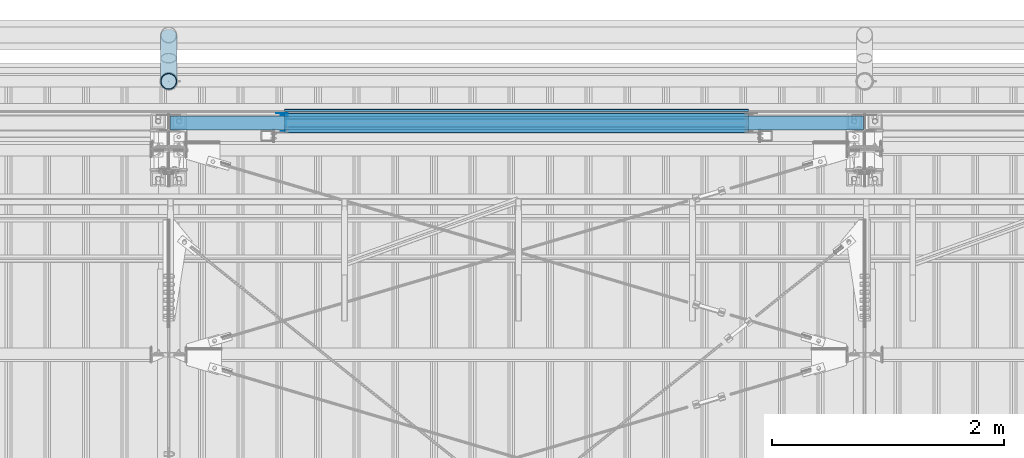
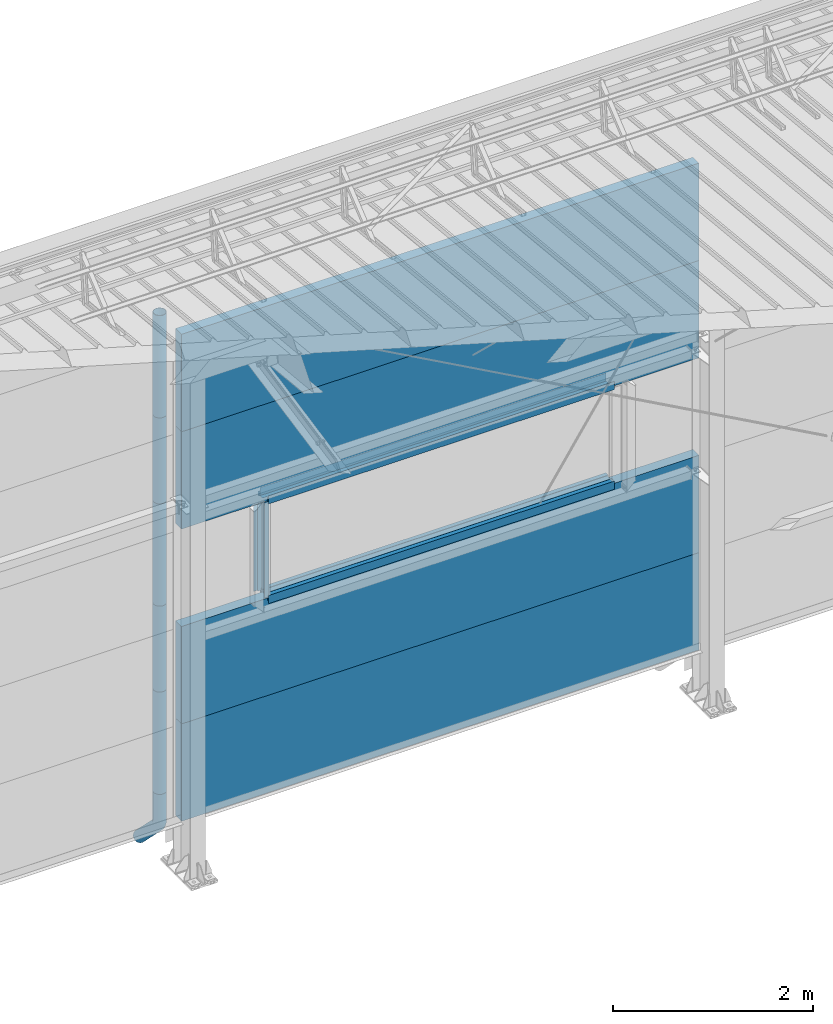
# One storey, part 78 of 709: 19 beams, 19 elements without a shape of their own.
"""IFC4 building model written with IfcOpenShell, lengths in millimetres."""

from ifc_helpers import new_model, entity, si_unit, direction, frame, origin_with_axes, place, context, subcontext, project, spatial, line, indexed_curve, outline, extrude, material, element, aggregate, save


model = new_model("IFC4")

# Units and contexts
model_context = context("Model", 3, precision=0.2, world=origin_with_axes(), true_north=direction((0.0, 1.0)))
body_context = subcontext(model_context, "Body", "Model", "MODEL_VIEW")
ifc_project = project(units=[si_unit("LENGTHUNIT", "METRE", prefix="MILLI"), si_unit("AREAUNIT", "SQUARE_METRE"), si_unit("VOLUMEUNIT", "CUBIC_METRE"), si_unit("MASSUNIT", "GRAM", prefix="KILO"), si_unit("TIMEUNIT", "SECOND"), si_unit("PLANEANGLEUNIT", "RADIAN"), si_unit("SOLIDANGLEUNIT", "STERADIAN"), si_unit("THERMODYNAMICTEMPERATUREUNIT", "DEGREE_CELSIUS"), si_unit("LUMINOUSINTENSITYUNIT", "LUMEN")], contexts=[model_context])

# Site, building, storey
site_placement = place(None, origin_with_axes())
site = spatial("IfcSite", under=ifc_project, at=site_placement, CompositionType="ELEMENT")
building_placement = place(site_placement, origin_with_axes())
building = spatial("IfcBuilding", under=site, at=building_placement, Name="Undefined", CompositionType="ELEMENT")
storey_placement = place(building_placement, origin_with_axes())
storey = spatial("IfcBuildingStorey", under=building, at=storey_placement, Name="Undefined", CompositionType="ELEMENT", Elevation=0.0)

# Assembly, beam
assembly_1_placement = place(storey_placement, frame((40010.0, 22060.0, 895.0), z_axis=(0.0, 0.0, -1.0), x_axis=(1.0, 0.0, 0.0)))
assembly_1 = element("IfcElementAssembly", 1, at=assembly_1_placement, inside=storey)
ifc_material_1 = material(Name="Insulation", Category="Insulation")
beam_1_placement = place(assembly_1_placement, origin_with_axes())
beam_1 = element("IfcBeam", 2, at=beam_1_placement, material=ifc_material_1, ObjectType="P-107", context=body_context, shape_type="SolidModel", body=[
    extrude(outline(indexed_curve([(-595.0, -60.0), (595.0, -60.0), (595.0, 60.0), (-595.0, 60.0)], segments=[line(1, 2, 3, 4, 1)])), frame((0.0, 0.0, 0.0), z_axis=(-1.0, 0.0, 0.0), x_axis=(0.0, 0.0, 1.0)), (0.0, 0.0, -1.0), 5980.0),
])
aggregate(assembly_1, [beam_1])

assembly_2_placement = place(storey_placement, frame((40010.0, 22060.0, 2085.0), z_axis=(0.0, 0.0, -1.0), x_axis=(1.0, 0.0, 0.0)))
assembly_2 = element("IfcElementAssembly", 3, at=assembly_2_placement, inside=storey)
beam_2_placement = place(assembly_2_placement, origin_with_axes())
beam_2 = element("IfcBeam", 4, at=beam_2_placement, material=ifc_material_1, ObjectType="P-107", context=body_context, shape_type="SolidModel", body=[
    extrude(outline(indexed_curve([(-595.0, -60.0), (595.0, -60.0), (595.0, 60.0), (-595.0, 60.0)], segments=[line(1, 2, 3, 4, 1)])), frame((0.0, 0.0, 0.0), z_axis=(-1.0, 0.0, 0.0), x_axis=(0.0, 0.0, 1.0)), (0.0, 0.0, -1.0), 5980.0),
])
aggregate(assembly_2, [beam_2])

assembly_3_placement = place(storey_placement, frame((40010.0, 22060.0, 4465.0), z_axis=(0.0, 0.0, -1.0), x_axis=(1.0, 0.0, 0.0)))
assembly_3 = element("IfcElementAssembly", 5, at=assembly_3_placement, inside=storey)
beam_3_placement = place(assembly_3_placement, origin_with_axes())
beam_3 = element("IfcBeam", 6, at=beam_3_placement, material=ifc_material_1, ObjectType="P-107", context=body_context, shape_type="SolidModel", body=[
    extrude(outline(indexed_curve([(-595.0, -60.0), (595.0, -60.0), (595.0, 60.0), (-595.0, 60.0)], segments=[line(1, 2, 3, 4, 1)])), frame((0.0, 0.0, 0.0), z_axis=(-1.0, 0.0, 0.0), x_axis=(0.0, 0.0, 1.0)), (0.0, 0.0, -1.0), 5980.0),
])
aggregate(assembly_3, [beam_3])

assembly_4_placement = place(storey_placement, frame((40010.0, 22060.0, 5655.0), z_axis=(0.0, 0.0, -1.0), x_axis=(1.0, 0.0, 0.0)))
assembly_4 = element("IfcElementAssembly", 7, at=assembly_4_placement, inside=storey)
beam_4_placement = place(assembly_4_placement, origin_with_axes())
beam_4 = element("IfcBeam", 8, at=beam_4_placement, material=ifc_material_1, ObjectType="P-107", context=body_context, shape_type="SolidModel", body=[
    extrude(outline(indexed_curve([(-595.0, -60.0), (595.0, -60.0), (595.0, 60.0), (-595.0, 60.0)], segments=[line(1, 2, 3, 4, 1)])), frame((0.0, 0.0, 0.0), z_axis=(-1.0, 0.0, 0.0), x_axis=(0.0, 0.0, 1.0)), (0.0, 0.0, -1.0), 5980.0),
])
aggregate(assembly_4, [beam_4])

assembly_5_placement = place(storey_placement, frame((45000.0, 22001.0, 2725.0), z_axis=(0.0, -1.0, 0.0), x_axis=(-1.0, 0.0, 0.0)))
assembly_5 = element("IfcElementAssembly", 9, at=assembly_5_placement, inside=storey)
ifc_material_2 = material(Name="Steel_Undefined", Category="STEEL")
beam_5_placement = place(assembly_5_placement, origin_with_axes())
beam_5 = element("IfcBeam", 10, at=beam_5_placement, material=ifc_material_2, context=body_context, shape_type="SolidModel", body=[
    extrude(outline(indexed_curve([(-25.0, -1.0), (25.0, -1.0), (25.0, 99.0), (23.0, 99.0), (23.0, 1.0), (-25.0, 1.0)], segments=[line(1, 2, 3, 4, 5, 6, 1)])), frame((0.0, 0.0, 0.0), z_axis=(-1.0, 0.0, 0.0), x_axis=(0.0, 0.0, 1.0)), (0.0, 0.0, -1.0), 4000.0),
])
aggregate(assembly_5, [beam_5])

assembly_6_placement = place(storey_placement, frame((45000.0, 22060.0, 2680.0), z_axis=(0.0, 1.0, 0.0), x_axis=(-1.0, 0.0, 0.0)))
assembly_6 = element("IfcElementAssembly", 11, at=assembly_6_placement, inside=storey)
beam_6_placement = place(assembly_6_placement, origin_with_axes())
beam_6 = element("IfcBeam", 12, at=beam_6_placement, material=ifc_material_2, context=body_context, shape_type="SolidModel", body=[
    extrude(outline(indexed_curve([(-70.0, -25.0), (-68.0, -25.0), (-68.0, 23.0), (68.0, 23.0), (68.0, -25.0), (70.0, -25.0), (70.0, 25.0), (-70.0, 25.0)], segments=[line(1, 2, 3, 4, 5, 6, 7, 8, 1)])), frame((0.0, 0.0, 0.0), z_axis=(-1.0, 0.0, 0.0), x_axis=(0.0, 0.0, 1.0)), (0.0, 0.0, -1.0), 4000.0),
])
aggregate(assembly_6, [beam_6])

assembly_7_placement = place(storey_placement, frame((41000.0, 22121.0, 2725.0), z_axis=(0.0, 1.0, 0.0), x_axis=(1.0, 0.0, 0.0)))
assembly_7 = element("IfcElementAssembly", 13, at=assembly_7_placement, inside=storey)
beam_7_placement = place(assembly_7_placement, origin_with_axes())
beam_7 = element("IfcBeam", 14, at=beam_7_placement, material=ifc_material_2, context=body_context, shape_type="SolidModel", body=[
    extrude(outline(indexed_curve([(-25.0, -1.0), (25.0, -1.0), (25.0, 99.0), (23.0, 99.0), (23.0, 1.0), (-25.0, 1.0)], segments=[line(1, 2, 3, 4, 5, 6, 1)])), frame((0.0, 0.0, 0.0), z_axis=(-1.0, 0.0, 0.0), x_axis=(0.0, 0.0, 1.0)), (0.0, 0.0, -1.0), 4000.0),
])
aggregate(assembly_7, [beam_7])

assembly_8_placement = place(storey_placement, frame((41000.0, 22001.0, 3845.0), z_axis=(0.0, -1.0, 0.0), x_axis=(1.0, 0.0, 0.0)))
assembly_8 = element("IfcElementAssembly", 15, at=assembly_8_placement, inside=storey)
beam_8_placement = place(assembly_8_placement, origin_with_axes())
beam_8 = element("IfcBeam", 16, at=beam_8_placement, material=ifc_material_2, context=body_context, shape_type="SolidModel", body=[
    extrude(outline(indexed_curve([(-25.0, -1.0), (25.0, -1.0), (25.0, 99.0), (23.0, 99.0), (23.0, 1.0), (-25.0, 1.0)], segments=[line(1, 2, 3, 4, 5, 6, 1)])), frame((0.0, 0.0, 0.0), z_axis=(-1.0, 0.0, 0.0), x_axis=(0.0, 0.0, 1.0)), (0.0, 0.0, -1.0), 4000.0),
])
aggregate(assembly_8, [beam_8])

assembly_9_placement = place(storey_placement, frame((45000.0, 22060.0, 3890.0), z_axis=(0.0, -1.0, 0.0), x_axis=(-1.0, 0.0, 0.0)))
assembly_9 = element("IfcElementAssembly", 17, at=assembly_9_placement, inside=storey)
beam_9_placement = place(assembly_9_placement, origin_with_axes())
beam_9 = element("IfcBeam", 18, at=beam_9_placement, material=ifc_material_2, context=body_context, shape_type="SolidModel", body=[
    extrude(outline(indexed_curve([(-70.0, -25.0), (-68.0, -25.0), (-68.0, 23.0), (68.0, 23.0), (68.0, -25.0), (70.0, -25.0), (70.0, 25.0), (-70.0, 25.0)], segments=[line(1, 2, 3, 4, 5, 6, 7, 8, 1)])), frame((0.0, 0.0, 0.0), z_axis=(-1.0, 0.0, 0.0), x_axis=(0.0, 0.0, 1.0)), (0.0, 0.0, -1.0), 4000.0),
])
aggregate(assembly_9, [beam_9])

assembly_10_placement = place(storey_placement, frame((45000.0, 22121.0, 3845.0), z_axis=(0.0, 1.0, 0.0), x_axis=(-1.0, 0.0, 0.0)))
assembly_10 = element("IfcElementAssembly", 19, at=assembly_10_placement, inside=storey)
beam_10_placement = place(assembly_10_placement, origin_with_axes())
beam_10 = element("IfcBeam", 20, at=beam_10_placement, material=ifc_material_2, context=body_context, shape_type="SolidModel", body=[
    extrude(outline(indexed_curve([(-25.0, -1.0), (25.0, -1.0), (25.0, 99.0), (23.0, 99.0), (23.0, 1.0), (-25.0, 1.0)], segments=[line(1, 2, 3, 4, 5, 6, 1)])), frame((0.0, 0.0, 0.0), z_axis=(-1.0, 0.0, 0.0), x_axis=(0.0, 0.0, 1.0)), (0.0, 0.0, -1.0), 4000.0),
])
aggregate(assembly_10, [beam_10])

assembly_11_placement = place(storey_placement, frame((45000.0, 22171.0, 3830.0), z_axis=(0.0, 1.0, 0.0), x_axis=(-1.0, 0.0, 0.0)))
assembly_11 = element("IfcElementAssembly", 21, at=assembly_11_placement, inside=storey)
beam_11_placement = place(assembly_11_placement, origin_with_axes())
beam_11 = element("IfcBeam", 22, at=beam_11_placement, material=ifc_material_2, context=body_context, shape_type="SolidModel", body=[
    extrude(outline(indexed_curve([(-10.0, -1.0), (10.0, -1.0), (10.0, 49.0), (8.0, 49.0), (8.0, 1.0), (-10.0, 1.0)], segments=[line(1, 2, 3, 4, 5, 6, 1)])), frame((0.0, 0.0, 0.0), z_axis=(-1.0, 0.0, 0.0), x_axis=(0.0, 0.0, 1.0)), (0.0, 0.0, -1.0), 4000.0),
])
aggregate(assembly_11, [beam_11])

assembly_12_placement = place(storey_placement, frame((40990.0, 22060.0, 3870.0), z_axis=(0.0, -1.0, 0.0), x_axis=(0.0, 0.0, -1.0)))
assembly_12 = element("IfcElementAssembly", 23, at=assembly_12_placement, inside=storey)
beam_12_placement = place(assembly_12_placement, origin_with_axes())
beam_12 = element("IfcBeam", 24, at=beam_12_placement, material=ifc_material_2, context=body_context, shape_type="SolidModel", body=[
    extrude(outline(indexed_curve([(-70.0, -25.0), (-68.0, -25.0), (-68.0, 23.0), (68.0, 23.0), (68.0, -25.0), (70.0, -25.0), (70.0, 25.0), (-70.0, 25.0)], segments=[line(1, 2, 3, 4, 5, 6, 7, 8, 1)])), frame((0.0, 0.0, 0.0), z_axis=(-1.0, 0.0, 0.0), x_axis=(0.0, 0.0, 1.0)), (0.0, 0.0, -1.0), 1170.0),
])
aggregate(assembly_12, [beam_12])

assembly_13_placement = place(storey_placement, frame((41025.0, 22121.0, 3870.0), z_axis=(0.0, 1.0, 0.0), x_axis=(0.0, 0.0, -1.0)))
assembly_13 = element("IfcElementAssembly", 25, at=assembly_13_placement, inside=storey)
beam_13_placement = place(assembly_13_placement, origin_with_axes())
beam_13 = element("IfcBeam", 26, at=beam_13_placement, material=ifc_material_2, context=body_context, shape_type="SolidModel", body=[
    extrude(outline(indexed_curve([(-25.0, -1.0), (25.0, -1.0), (25.0, 99.0), (23.0, 99.0), (23.0, 1.0), (-25.0, 1.0)], segments=[line(1, 2, 3, 4, 5, 6, 1)])), frame((0.0, 0.0, 0.0), z_axis=(-1.0, 0.0, 0.0), x_axis=(0.0, 0.0, 1.0)), (0.0, 0.0, -1.0), 1170.0),
])
aggregate(assembly_13, [beam_13])

assembly_14_placement = place(storey_placement, frame((40000.0, 22420.0, 6276.92297), z_axis=(0.0, -1.0, 0.0), x_axis=(0.0, 0.0, -1.0)))
assembly_14 = element("IfcElementAssembly", 27, at=assembly_14_placement, inside=storey)
beam_14_placement = place(assembly_14_placement, origin_with_axes())
beam_14 = element("IfcBeam", 28, at=beam_14_placement, material=ifc_material_2, ObjectType="614", context=body_context, shape_type="SolidModel", body=[
    extrude(outline(indexed_curve([(70.0, 0.0), (69.61653, 7.31699), (68.47033, 14.55382), (66.57396, 21.63119), (63.94818, 28.47157), (60.62178, 35.0), (56.63119, 41.14497), (52.02014, 46.83914), (46.83914, 52.02014), (41.14497, 56.63119), (35.0, 60.62178), (28.47157, 63.94818), (21.63119, 66.57396), (14.55382, 68.47033), (7.31699, 69.61653), (0.0, 70.0), (-7.31699, 69.61653), (-14.55382, 68.47033), (-21.63119, 66.57396), (-28.47157, 63.94818), (-35.0, 60.62178), (-41.14497, 56.63119), (-46.83914, 52.02014), (-52.02014, 46.83914), (-56.63119, 41.14497), (-60.62178, 35.0), (-63.94818, 28.47157), (-66.57396, 21.63119), (-68.47033, 14.55382), (-69.61653, 7.31699), (-70.0, 0.0), (-69.61653, -7.31699), (-68.47033, -14.55382), (-66.57396, -21.63119), (-63.94818, -28.47157), (-60.62178, -35.0), (-56.63119, -41.14497), (-52.02014, -46.83914), (-46.83914, -52.02014), (-41.14497, -56.63119), (-35.0, -60.62178), (-28.47157, -63.94818), (-21.63119, -66.57396), (-14.55382, -68.47033), (-7.31699, -69.61653), (0.0, -70.0), (7.31699, -69.61653), (14.55382, -68.47033), (21.63119, -66.57396), (28.47157, -63.94818), (35.0, -60.62178), (41.14497, -56.63119), (46.83914, -52.02014), (52.02014, -46.83914), (56.63119, -41.14497), (60.62178, -35.0), (63.94818, -28.47157), (66.57396, -21.63119), (68.47033, -14.55382), (69.61653, -7.31699)], segments=[line(1, 2, 3, 4, 5, 6, 7, 8, 9, 10, 11, 12, 13, 14, 15, 16, 17, 18, 19, 20, 21, 22, 23, 24, 25, 26, 27, 28, 29, 30, 31, 32, 33, 34, 35, 36, 37, 38, 39, 40, 41, 42, 43, 44, 45, 46, 47, 48, 49, 50, 51, 52, 53, 54, 55, 56, 57, 58, 59, 60, 1)]), holes=[indexed_curve([(65.0, 0.0), (64.64392, -6.79435), (63.57959, -13.51426), (61.81867, -20.0861), (59.38045, -26.43788), (56.29165, -32.5), (52.5861, -38.20604), (48.30441, -43.49349), (43.49349, -48.30441), (38.20604, -52.5861), (32.5, -56.29165), (26.43788, -59.38045), (20.0861, -61.81867), (13.51426, -63.57959), (6.79435, -64.64392), (0.0, -65.0), (-6.79435, -64.64392), (-13.51426, -63.57959), (-20.0861, -61.81867), (-26.43788, -59.38045), (-32.5, -56.29165), (-38.20604, -52.5861), (-43.49349, -48.30441), (-48.30441, -43.49349), (-52.5861, -38.20604), (-56.29165, -32.5), (-59.38045, -26.43788), (-61.81867, -20.0861), (-63.57959, -13.51426), (-64.64392, -6.79435), (-65.0, 0.0), (-64.64392, 6.79435), (-63.57959, 13.51426), (-61.81867, 20.0861), (-59.38045, 26.43788), (-56.29165, 32.5), (-52.5861, 38.20604), (-48.30441, 43.49349), (-43.49349, 48.30441), (-38.20604, 52.5861), (-32.5, 56.29165), (-26.43788, 59.38045), (-20.0861, 61.81867), (-13.51426, 63.57959), (-6.79435, 64.64392), (0.0, 65.0), (6.79435, 64.64392), (13.51426, 63.57959), (20.0861, 61.81867), (26.43788, 59.38045), (32.5, 56.29165), (38.20604, 52.5861), (43.49349, 48.30441), (48.30441, 43.49349), (52.5861, 38.20604), (56.29165, 32.5), (59.38045, 26.43788), (61.81867, 20.0861), (63.57959, 13.51426), (64.64392, 6.79435)], segments=[line(1, 2, 3, 4, 5, 6, 7, 8, 9, 10, 11, 12, 13, 14, 15, 16, 17, 18, 19, 20, 21, 22, 23, 24, 25, 26, 27, 28, 29, 30, 31, 32, 33, 34, 35, 36, 37, 38, 39, 40, 41, 42, 43, 44, 45, 46, 47, 48, 49, 50, 51, 52, 53, 54, 55, 56, 57, 58, 59, 60, 1)])]), frame((0.0, 0.0, 0.0), z_axis=(-1.0, 0.0, 0.0), x_axis=(0.0, 0.0, 1.0)), (0.0, 0.0, -1.0), 1250.0),
])
aggregate(assembly_14, [beam_14])

assembly_15_placement = place(storey_placement, frame((40000.0, 22420.0, 5126.92297), z_axis=(0.0, -1.0, 0.0), x_axis=(0.0, 0.0, -1.0)))
assembly_15 = element("IfcElementAssembly", 29, at=assembly_15_placement, inside=storey)
beam_15_placement = place(assembly_15_placement, origin_with_axes())
beam_15 = element("IfcBeam", 30, at=beam_15_placement, material=ifc_material_2, ObjectType="614", context=body_context, shape_type="SolidModel", body=[
    extrude(outline(indexed_curve([(70.0, 0.0), (69.61653, 7.31699), (68.47033, 14.55382), (66.57396, 21.63119), (63.94818, 28.47157), (60.62178, 35.0), (56.63119, 41.14497), (52.02014, 46.83914), (46.83914, 52.02014), (41.14497, 56.63119), (35.0, 60.62178), (28.47157, 63.94818), (21.63119, 66.57396), (14.55382, 68.47033), (7.31699, 69.61653), (0.0, 70.0), (-7.31699, 69.61653), (-14.55382, 68.47033), (-21.63119, 66.57396), (-28.47157, 63.94818), (-35.0, 60.62178), (-41.14497, 56.63119), (-46.83914, 52.02014), (-52.02014, 46.83914), (-56.63119, 41.14497), (-60.62178, 35.0), (-63.94818, 28.47157), (-66.57396, 21.63119), (-68.47033, 14.55382), (-69.61653, 7.31699), (-70.0, 0.0), (-69.61653, -7.31699), (-68.47033, -14.55382), (-66.57396, -21.63119), (-63.94818, -28.47157), (-60.62178, -35.0), (-56.63119, -41.14497), (-52.02014, -46.83914), (-46.83914, -52.02014), (-41.14497, -56.63119), (-35.0, -60.62178), (-28.47157, -63.94818), (-21.63119, -66.57396), (-14.55382, -68.47033), (-7.31699, -69.61653), (0.0, -70.0), (7.31699, -69.61653), (14.55382, -68.47033), (21.63119, -66.57396), (28.47157, -63.94818), (35.0, -60.62178), (41.14497, -56.63119), (46.83914, -52.02014), (52.02014, -46.83914), (56.63119, -41.14497), (60.62178, -35.0), (63.94818, -28.47157), (66.57396, -21.63119), (68.47033, -14.55382), (69.61653, -7.31699)], segments=[line(1, 2, 3, 4, 5, 6, 7, 8, 9, 10, 11, 12, 13, 14, 15, 16, 17, 18, 19, 20, 21, 22, 23, 24, 25, 26, 27, 28, 29, 30, 31, 32, 33, 34, 35, 36, 37, 38, 39, 40, 41, 42, 43, 44, 45, 46, 47, 48, 49, 50, 51, 52, 53, 54, 55, 56, 57, 58, 59, 60, 1)]), holes=[indexed_curve([(65.0, 0.0), (64.64392, -6.79435), (63.57959, -13.51426), (61.81867, -20.0861), (59.38045, -26.43788), (56.29165, -32.5), (52.5861, -38.20604), (48.30441, -43.49349), (43.49349, -48.30441), (38.20604, -52.5861), (32.5, -56.29165), (26.43788, -59.38045), (20.0861, -61.81867), (13.51426, -63.57959), (6.79435, -64.64392), (0.0, -65.0), (-6.79435, -64.64392), (-13.51426, -63.57959), (-20.0861, -61.81867), (-26.43788, -59.38045), (-32.5, -56.29165), (-38.20604, -52.5861), (-43.49349, -48.30441), (-48.30441, -43.49349), (-52.5861, -38.20604), (-56.29165, -32.5), (-59.38045, -26.43788), (-61.81867, -20.0861), (-63.57959, -13.51426), (-64.64392, -6.79435), (-65.0, 0.0), (-64.64392, 6.79435), (-63.57959, 13.51426), (-61.81867, 20.0861), (-59.38045, 26.43788), (-56.29165, 32.5), (-52.5861, 38.20604), (-48.30441, 43.49349), (-43.49349, 48.30441), (-38.20604, 52.5861), (-32.5, 56.29165), (-26.43788, 59.38045), (-20.0861, 61.81867), (-13.51426, 63.57959), (-6.79435, 64.64392), (0.0, 65.0), (6.79435, 64.64392), (13.51426, 63.57959), (20.0861, 61.81867), (26.43788, 59.38045), (32.5, 56.29165), (38.20604, 52.5861), (43.49349, 48.30441), (48.30441, 43.49349), (52.5861, 38.20604), (56.29165, 32.5), (59.38045, 26.43788), (61.81867, 20.0861), (63.57959, 13.51426), (64.64392, 6.79435)], segments=[line(1, 2, 3, 4, 5, 6, 7, 8, 9, 10, 11, 12, 13, 14, 15, 16, 17, 18, 19, 20, 21, 22, 23, 24, 25, 26, 27, 28, 29, 30, 31, 32, 33, 34, 35, 36, 37, 38, 39, 40, 41, 42, 43, 44, 45, 46, 47, 48, 49, 50, 51, 52, 53, 54, 55, 56, 57, 58, 59, 60, 1)])]), frame((0.0, 0.0, 0.0), z_axis=(-1.0, 0.0, 0.0), x_axis=(0.0, 0.0, 1.0)), (0.0, 0.0, -1.0), 1250.0),
])
aggregate(assembly_15, [beam_15])

assembly_16_placement = place(storey_placement, frame((40000.0, 22420.0, 3976.92297), z_axis=(0.0, -1.0, 0.0), x_axis=(0.0, 0.0, -1.0)))
assembly_16 = element("IfcElementAssembly", 31, at=assembly_16_placement, inside=storey)
beam_16_placement = place(assembly_16_placement, origin_with_axes())
beam_16 = element("IfcBeam", 32, at=beam_16_placement, material=ifc_material_2, ObjectType="614", context=body_context, shape_type="SolidModel", body=[
    extrude(outline(indexed_curve([(70.0, 0.0), (69.61653, 7.31699), (68.47033, 14.55382), (66.57396, 21.63119), (63.94818, 28.47157), (60.62178, 35.0), (56.63119, 41.14497), (52.02014, 46.83914), (46.83914, 52.02014), (41.14497, 56.63119), (35.0, 60.62178), (28.47157, 63.94818), (21.63119, 66.57396), (14.55382, 68.47033), (7.31699, 69.61653), (0.0, 70.0), (-7.31699, 69.61653), (-14.55382, 68.47033), (-21.63119, 66.57396), (-28.47157, 63.94818), (-35.0, 60.62178), (-41.14497, 56.63119), (-46.83914, 52.02014), (-52.02014, 46.83914), (-56.63119, 41.14497), (-60.62178, 35.0), (-63.94818, 28.47157), (-66.57396, 21.63119), (-68.47033, 14.55382), (-69.61653, 7.31699), (-70.0, 0.0), (-69.61653, -7.31699), (-68.47033, -14.55382), (-66.57396, -21.63119), (-63.94818, -28.47157), (-60.62178, -35.0), (-56.63119, -41.14497), (-52.02014, -46.83914), (-46.83914, -52.02014), (-41.14497, -56.63119), (-35.0, -60.62178), (-28.47157, -63.94818), (-21.63119, -66.57396), (-14.55382, -68.47033), (-7.31699, -69.61653), (0.0, -70.0), (7.31699, -69.61653), (14.55382, -68.47033), (21.63119, -66.57396), (28.47157, -63.94818), (35.0, -60.62178), (41.14497, -56.63119), (46.83914, -52.02014), (52.02014, -46.83914), (56.63119, -41.14497), (60.62178, -35.0), (63.94818, -28.47157), (66.57396, -21.63119), (68.47033, -14.55382), (69.61653, -7.31699)], segments=[line(1, 2, 3, 4, 5, 6, 7, 8, 9, 10, 11, 12, 13, 14, 15, 16, 17, 18, 19, 20, 21, 22, 23, 24, 25, 26, 27, 28, 29, 30, 31, 32, 33, 34, 35, 36, 37, 38, 39, 40, 41, 42, 43, 44, 45, 46, 47, 48, 49, 50, 51, 52, 53, 54, 55, 56, 57, 58, 59, 60, 1)]), holes=[indexed_curve([(65.0, 0.0), (64.64392, -6.79435), (63.57959, -13.51426), (61.81867, -20.0861), (59.38045, -26.43788), (56.29165, -32.5), (52.5861, -38.20604), (48.30441, -43.49349), (43.49349, -48.30441), (38.20604, -52.5861), (32.5, -56.29165), (26.43788, -59.38045), (20.0861, -61.81867), (13.51426, -63.57959), (6.79435, -64.64392), (0.0, -65.0), (-6.79435, -64.64392), (-13.51426, -63.57959), (-20.0861, -61.81867), (-26.43788, -59.38045), (-32.5, -56.29165), (-38.20604, -52.5861), (-43.49349, -48.30441), (-48.30441, -43.49349), (-52.5861, -38.20604), (-56.29165, -32.5), (-59.38045, -26.43788), (-61.81867, -20.0861), (-63.57959, -13.51426), (-64.64392, -6.79435), (-65.0, 0.0), (-64.64392, 6.79435), (-63.57959, 13.51426), (-61.81867, 20.0861), (-59.38045, 26.43788), (-56.29165, 32.5), (-52.5861, 38.20604), (-48.30441, 43.49349), (-43.49349, 48.30441), (-38.20604, 52.5861), (-32.5, 56.29165), (-26.43788, 59.38045), (-20.0861, 61.81867), (-13.51426, 63.57959), (-6.79435, 64.64392), (0.0, 65.0), (6.79435, 64.64392), (13.51426, 63.57959), (20.0861, 61.81867), (26.43788, 59.38045), (32.5, 56.29165), (38.20604, 52.5861), (43.49349, 48.30441), (48.30441, 43.49349), (52.5861, 38.20604), (56.29165, 32.5), (59.38045, 26.43788), (61.81867, 20.0861), (63.57959, 13.51426), (64.64392, 6.79435)], segments=[line(1, 2, 3, 4, 5, 6, 7, 8, 9, 10, 11, 12, 13, 14, 15, 16, 17, 18, 19, 20, 21, 22, 23, 24, 25, 26, 27, 28, 29, 30, 31, 32, 33, 34, 35, 36, 37, 38, 39, 40, 41, 42, 43, 44, 45, 46, 47, 48, 49, 50, 51, 52, 53, 54, 55, 56, 57, 58, 59, 60, 1)])]), frame((0.0, 0.0, 0.0), z_axis=(-1.0, 0.0, 0.0), x_axis=(0.0, 0.0, 1.0)), (0.0, 0.0, -1.0), 1250.0),
])
aggregate(assembly_16, [beam_16])

assembly_17_placement = place(storey_placement, frame((40000.0, 22420.0, 2826.92297), z_axis=(0.0, -1.0, 0.0), x_axis=(0.0, 0.0, -1.0)))
assembly_17 = element("IfcElementAssembly", 33, at=assembly_17_placement, inside=storey)
beam_17_placement = place(assembly_17_placement, origin_with_axes())
beam_17 = element("IfcBeam", 34, at=beam_17_placement, material=ifc_material_2, ObjectType="614", context=body_context, shape_type="SolidModel", body=[
    extrude(outline(indexed_curve([(70.0, 0.0), (69.61653, 7.31699), (68.47033, 14.55382), (66.57396, 21.63119), (63.94818, 28.47157), (60.62178, 35.0), (56.63119, 41.14497), (52.02014, 46.83914), (46.83914, 52.02014), (41.14497, 56.63119), (35.0, 60.62178), (28.47157, 63.94818), (21.63119, 66.57396), (14.55382, 68.47033), (7.31699, 69.61653), (0.0, 70.0), (-7.31699, 69.61653), (-14.55382, 68.47033), (-21.63119, 66.57396), (-28.47157, 63.94818), (-35.0, 60.62178), (-41.14497, 56.63119), (-46.83914, 52.02014), (-52.02014, 46.83914), (-56.63119, 41.14497), (-60.62178, 35.0), (-63.94818, 28.47157), (-66.57396, 21.63119), (-68.47033, 14.55382), (-69.61653, 7.31699), (-70.0, 0.0), (-69.61653, -7.31699), (-68.47033, -14.55382), (-66.57396, -21.63119), (-63.94818, -28.47157), (-60.62178, -35.0), (-56.63119, -41.14497), (-52.02014, -46.83914), (-46.83914, -52.02014), (-41.14497, -56.63119), (-35.0, -60.62178), (-28.47157, -63.94818), (-21.63119, -66.57396), (-14.55382, -68.47033), (-7.31699, -69.61653), (0.0, -70.0), (7.31699, -69.61653), (14.55382, -68.47033), (21.63119, -66.57396), (28.47157, -63.94818), (35.0, -60.62178), (41.14497, -56.63119), (46.83914, -52.02014), (52.02014, -46.83914), (56.63119, -41.14497), (60.62178, -35.0), (63.94818, -28.47157), (66.57396, -21.63119), (68.47033, -14.55382), (69.61653, -7.31699)], segments=[line(1, 2, 3, 4, 5, 6, 7, 8, 9, 10, 11, 12, 13, 14, 15, 16, 17, 18, 19, 20, 21, 22, 23, 24, 25, 26, 27, 28, 29, 30, 31, 32, 33, 34, 35, 36, 37, 38, 39, 40, 41, 42, 43, 44, 45, 46, 47, 48, 49, 50, 51, 52, 53, 54, 55, 56, 57, 58, 59, 60, 1)]), holes=[indexed_curve([(65.0, 0.0), (64.64392, -6.79435), (63.57959, -13.51426), (61.81867, -20.0861), (59.38045, -26.43788), (56.29165, -32.5), (52.5861, -38.20604), (48.30441, -43.49349), (43.49349, -48.30441), (38.20604, -52.5861), (32.5, -56.29165), (26.43788, -59.38045), (20.0861, -61.81867), (13.51426, -63.57959), (6.79435, -64.64392), (0.0, -65.0), (-6.79435, -64.64392), (-13.51426, -63.57959), (-20.0861, -61.81867), (-26.43788, -59.38045), (-32.5, -56.29165), (-38.20604, -52.5861), (-43.49349, -48.30441), (-48.30441, -43.49349), (-52.5861, -38.20604), (-56.29165, -32.5), (-59.38045, -26.43788), (-61.81867, -20.0861), (-63.57959, -13.51426), (-64.64392, -6.79435), (-65.0, 0.0), (-64.64392, 6.79435), (-63.57959, 13.51426), (-61.81867, 20.0861), (-59.38045, 26.43788), (-56.29165, 32.5), (-52.5861, 38.20604), (-48.30441, 43.49349), (-43.49349, 48.30441), (-38.20604, 52.5861), (-32.5, 56.29165), (-26.43788, 59.38045), (-20.0861, 61.81867), (-13.51426, 63.57959), (-6.79435, 64.64392), (0.0, 65.0), (6.79435, 64.64392), (13.51426, 63.57959), (20.0861, 61.81867), (26.43788, 59.38045), (32.5, 56.29165), (38.20604, 52.5861), (43.49349, 48.30441), (48.30441, 43.49349), (52.5861, 38.20604), (56.29165, 32.5), (59.38045, 26.43788), (61.81867, 20.0861), (63.57959, 13.51426), (64.64392, 6.79435)], segments=[line(1, 2, 3, 4, 5, 6, 7, 8, 9, 10, 11, 12, 13, 14, 15, 16, 17, 18, 19, 20, 21, 22, 23, 24, 25, 26, 27, 28, 29, 30, 31, 32, 33, 34, 35, 36, 37, 38, 39, 40, 41, 42, 43, 44, 45, 46, 47, 48, 49, 50, 51, 52, 53, 54, 55, 56, 57, 58, 59, 60, 1)])]), frame((0.0, 0.0, 0.0), z_axis=(-1.0, 0.0, 0.0), x_axis=(0.0, 0.0, 1.0)), (0.0, 0.0, -1.0), 1250.0),
])
aggregate(assembly_17, [beam_17])

assembly_18_placement = place(storey_placement, frame((40000.0, 22420.0, 1676.92297), z_axis=(0.0, -1.0, 0.0), x_axis=(0.0, 0.0, -1.0)))
assembly_18 = element("IfcElementAssembly", 35, at=assembly_18_placement, inside=storey)
beam_18_placement = place(assembly_18_placement, origin_with_axes())
beam_18 = element("IfcBeam", 36, at=beam_18_placement, material=ifc_material_2, ObjectType="614", context=body_context, shape_type="SolidModel", body=[
    extrude(outline(indexed_curve([(70.0, 0.0), (69.61653, 7.31699), (68.47033, 14.55382), (66.57396, 21.63119), (63.94818, 28.47157), (60.62178, 35.0), (56.63119, 41.14497), (52.02014, 46.83914), (46.83914, 52.02014), (41.14497, 56.63119), (35.0, 60.62178), (28.47157, 63.94818), (21.63119, 66.57396), (14.55382, 68.47033), (7.31699, 69.61653), (0.0, 70.0), (-7.31699, 69.61653), (-14.55382, 68.47033), (-21.63119, 66.57396), (-28.47157, 63.94818), (-35.0, 60.62178), (-41.14497, 56.63119), (-46.83914, 52.02014), (-52.02014, 46.83914), (-56.63119, 41.14497), (-60.62178, 35.0), (-63.94818, 28.47157), (-66.57396, 21.63119), (-68.47033, 14.55382), (-69.61653, 7.31699), (-70.0, 0.0), (-69.61653, -7.31699), (-68.47033, -14.55382), (-66.57396, -21.63119), (-63.94818, -28.47157), (-60.62178, -35.0), (-56.63119, -41.14497), (-52.02014, -46.83914), (-46.83914, -52.02014), (-41.14497, -56.63119), (-35.0, -60.62178), (-28.47157, -63.94818), (-21.63119, -66.57396), (-14.55382, -68.47033), (-7.31699, -69.61653), (0.0, -70.0), (7.31699, -69.61653), (14.55382, -68.47033), (21.63119, -66.57396), (28.47157, -63.94818), (35.0, -60.62178), (41.14497, -56.63119), (46.83914, -52.02014), (52.02014, -46.83914), (56.63119, -41.14497), (60.62178, -35.0), (63.94818, -28.47157), (66.57396, -21.63119), (68.47033, -14.55382), (69.61653, -7.31699)], segments=[line(1, 2, 3, 4, 5, 6, 7, 8, 9, 10, 11, 12, 13, 14, 15, 16, 17, 18, 19, 20, 21, 22, 23, 24, 25, 26, 27, 28, 29, 30, 31, 32, 33, 34, 35, 36, 37, 38, 39, 40, 41, 42, 43, 44, 45, 46, 47, 48, 49, 50, 51, 52, 53, 54, 55, 56, 57, 58, 59, 60, 1)]), holes=[indexed_curve([(65.0, 0.0), (64.64392, -6.79435), (63.57959, -13.51426), (61.81867, -20.0861), (59.38045, -26.43788), (56.29165, -32.5), (52.5861, -38.20604), (48.30441, -43.49349), (43.49349, -48.30441), (38.20604, -52.5861), (32.5, -56.29165), (26.43788, -59.38045), (20.0861, -61.81867), (13.51426, -63.57959), (6.79435, -64.64392), (0.0, -65.0), (-6.79435, -64.64392), (-13.51426, -63.57959), (-20.0861, -61.81867), (-26.43788, -59.38045), (-32.5, -56.29165), (-38.20604, -52.5861), (-43.49349, -48.30441), (-48.30441, -43.49349), (-52.5861, -38.20604), (-56.29165, -32.5), (-59.38045, -26.43788), (-61.81867, -20.0861), (-63.57959, -13.51426), (-64.64392, -6.79435), (-65.0, 0.0), (-64.64392, 6.79435), (-63.57959, 13.51426), (-61.81867, 20.0861), (-59.38045, 26.43788), (-56.29165, 32.5), (-52.5861, 38.20604), (-48.30441, 43.49349), (-43.49349, 48.30441), (-38.20604, 52.5861), (-32.5, 56.29165), (-26.43788, 59.38045), (-20.0861, 61.81867), (-13.51426, 63.57959), (-6.79435, 64.64392), (0.0, 65.0), (6.79435, 64.64392), (13.51426, 63.57959), (20.0861, 61.81867), (26.43788, 59.38045), (32.5, 56.29165), (38.20604, 52.5861), (43.49349, 48.30441), (48.30441, 43.49349), (52.5861, 38.20604), (56.29165, 32.5), (59.38045, 26.43788), (61.81867, 20.0861), (63.57959, 13.51426), (64.64392, 6.79435)], segments=[line(1, 2, 3, 4, 5, 6, 7, 8, 9, 10, 11, 12, 13, 14, 15, 16, 17, 18, 19, 20, 21, 22, 23, 24, 25, 26, 27, 28, 29, 30, 31, 32, 33, 34, 35, 36, 37, 38, 39, 40, 41, 42, 43, 44, 45, 46, 47, 48, 49, 50, 51, 52, 53, 54, 55, 56, 57, 58, 59, 60, 1)])]), frame((0.0, 0.0, 0.0), z_axis=(-1.0, 0.0, 0.0), x_axis=(0.0, 0.0, 1.0)), (0.0, 0.0, -1.0), 1250.0),
])
aggregate(assembly_18, [beam_18])

assembly_19_placement = place(storey_placement, frame((40000.0, 22420.0, 526.92297), z_axis=(1.0, 0.0, 0.0), x_axis=(0.0, 0.0, -1.0)))
assembly_19 = element("IfcElementAssembly", 37, at=assembly_19_placement, inside=storey)
beam_19_placement = place(assembly_19_placement, origin_with_axes())
beam_19 = element("IfcBeam", 38, at=beam_19_placement, material=ifc_material_2, ObjectType="617", context=body_context, shape_type="SolidModel", body=[
    entity("IfcSweptDiskSolid", entity("IfcIndexedPolyCurve", entity("IfcCartesianPointList3D", [[0.0, 0.0, 0.0], [448.2233, 0.0, 0.0], [496.05873, 9.51506, 0.0], [536.61165, 36.61165, 0.0], [900.0, 400.0, 0.0]]), [entity("IfcLineIndex", [1, 2]), entity("IfcArcIndex", [2, 3, 4]), entity("IfcLineIndex", [4, 5])]), 70.0, 65.0),
])
aggregate(assembly_19, [beam_19])

save(model, "model.ifc")
